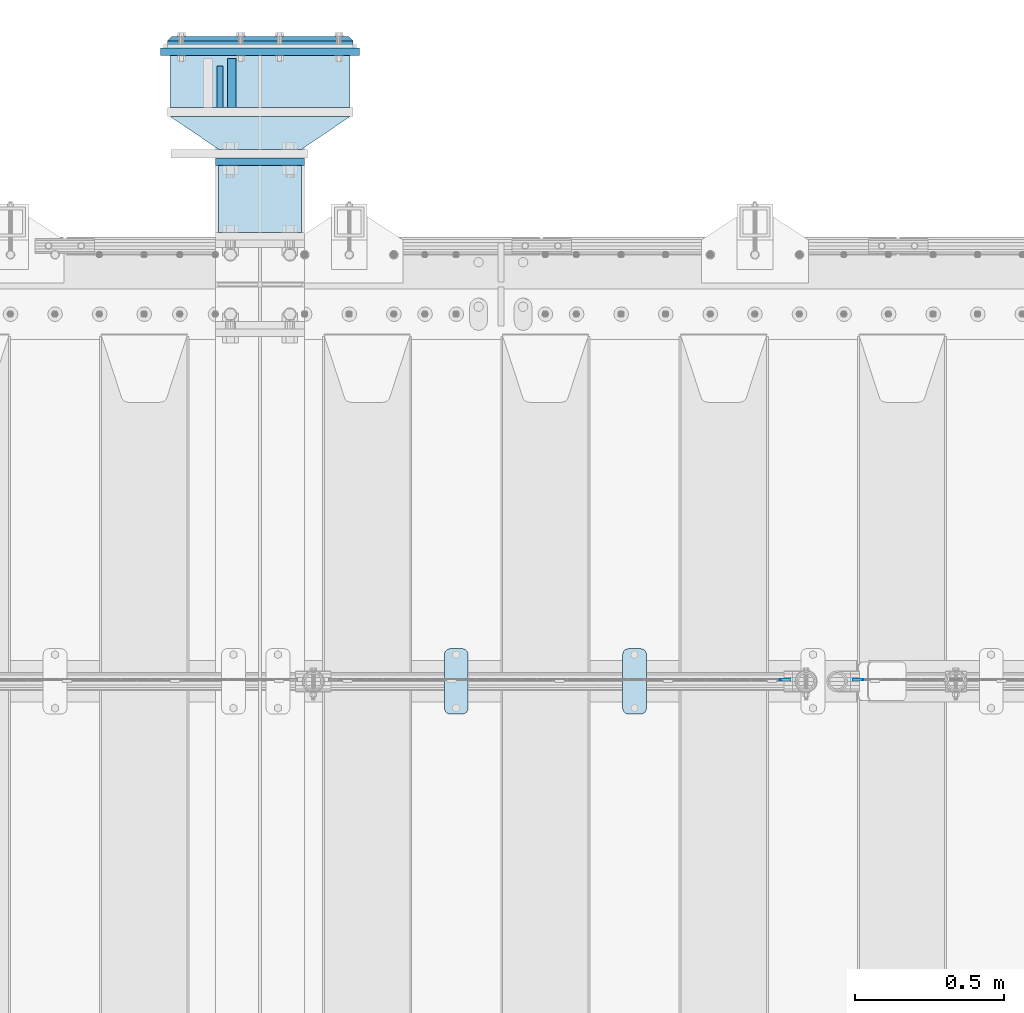
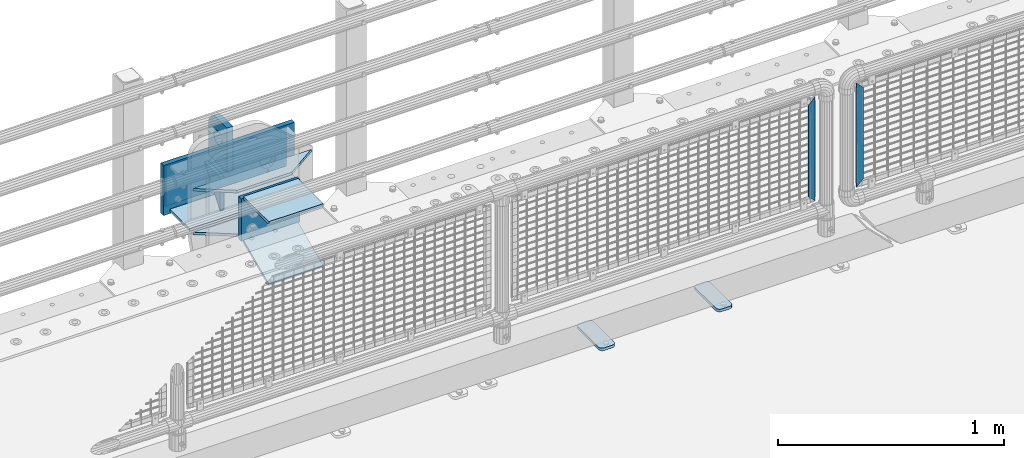
# One storey, part 201 of 219: 14 plates.
"""IFC2X3 building model written with IfcOpenShell, lengths in millimetres."""

import ifcopenshell
import ifcopenshell.guid

model = None  # the IFC model being written
_history = None  # IfcOwnerHistory: only IFC2X3 demands one
_inside = {}  # id of a spatial element -> (the spatial element, [elements in it])
_under = {}  # id of a project, library or spatial element -> (it, [spatial elements below it])
_declared = {}  # id of a project -> (the project, [libraries it declares])
_typed = {}  # id of a type object -> (the type object, [elements of that type])
_made_of = {}  # id of a material, layer set ... -> (it, [elements and type objects made of it])


def new_model(schema):
    """Start an empty IFC model of exactly this schema.

    Asked for "IFC4X3", IfcOpenShell would pick the latest addendum, in which some entities
    have other attributes; the version numbers below select the first issue.
    IFC2X3 requires an IfcOwnerHistory on every rooted entity: one is made here for all.
    """
    global model, _history
    if schema == "IFC4X3":
        model = ifcopenshell.file(schema_version=(4, 3, 0, 0))
    else:
        model = ifcopenshell.file(schema=schema)
    _inside.clear()
    _under.clear()
    _declared.clear()
    _typed.clear()
    _made_of.clear()
    _history = None
    if model.schema == "IFC2X3":
        org = make("IfcOrganization", Name="unknown")
        user = make(
            "IfcPersonAndOrganization",
            ThePerson=make("IfcPerson", FamilyName="unknown"),
            TheOrganization=org,
        )
        app = make(
            "IfcApplication",
            ApplicationDeveloper=org,
            Version="unknown",
            ApplicationFullName="unknown",
            ApplicationIdentifier="unknown",
        )
        _history = make(
            "IfcOwnerHistory",
            OwningUser=user,
            OwningApplication=app,
            ChangeAction="ADDED",
            CreationDate=0,
        )
    return model


def make(cls, **values):
    """One entity of the class cls with the attributes given. An attribute that is None is left unset."""
    return model.create_entity(
        cls, **{name: value for name, value in values.items() if value is not None}
    )


def rooted(cls, **values):
    """An entity with a GlobalId (a new one), such as an element, a storey or a relation."""
    return make(cls, GlobalId=ifcopenshell.guid.new(), OwnerHistory=_history, **values)


def si_unit(unit_type, name, prefix=None):
    """IfcSIUnit, for example si_unit("LENGTHUNIT", "METRE", prefix="MILLI")."""
    return make("IfcSIUnit", UnitType=unit_type, Prefix=prefix, Name=name)


def assignment(units):
    """IfcUnitAssignment: the units of a project."""
    return None if units is None else make("IfcUnitAssignment", Units=units)


def point(xyz):
    """IfcCartesianPoint."""
    return None if xyz is None else make("IfcCartesianPoint", Coordinates=xyz)


def direction(xyz):
    """IfcDirection."""
    return None if xyz is None else make("IfcDirection", DirectionRatios=xyz)


def frame(location, z_axis=None, x_axis=None):
    """IfcAxis2Placement3D, a coordinate frame: its origin and axes. An axis left out is left unset."""
    return make(
        "IfcAxis2Placement3D",
        Location=point(location),
        Axis=direction(z_axis),
        RefDirection=direction(x_axis),
    )


def origin_with_axes():
    """The frame at (0, 0, 0) with the z axis (0, 0, 1) and the x axis (1, 0, 0) written out."""
    return frame((0.0, 0.0, 0.0), z_axis=(0.0, 0.0, 1.0), x_axis=(1.0, 0.0, 0.0))


def place(relative_to, where):
    """IfcLocalPlacement: puts the frame where relative to a parent placement (None: the world)."""
    return make(
        "IfcLocalPlacement", PlacementRelTo=relative_to, RelativePlacement=where
    )


def context(
    kind, dimensions, precision=None, world=None, true_north=None, identifier=None
):
    """IfcGeometricRepresentationContext, for example the 3D "Model" context."""
    return make(
        "IfcGeometricRepresentationContext",
        ContextIdentifier=identifier,
        ContextType=kind,
        CoordinateSpaceDimension=dimensions,
        Precision=precision,
        WorldCoordinateSystem=world,
        TrueNorth=true_north,
    )


def subcontext(parent, identifier, kind, view, scale=None):
    """IfcGeometricRepresentationSubContext, for example "Body" below "Model"."""
    return make(
        "IfcGeometricRepresentationSubContext",
        ContextIdentifier=identifier,
        ContextType=kind,
        ParentContext=parent,
        TargetScale=scale,
        TargetView=view,
    )


def project(units=None, contexts=None):
    """IfcProject with its units and contexts."""
    return rooted(
        "IfcProject",
        Name="project",
        RepresentationContexts=contexts,
        UnitsInContext=assignment(units),
    )


def spatial(cls, under=None, at=None, **own):
    """A site, building, storey or space (cls), placed at a placement, below another one or the project."""
    s = rooted(cls, ObjectPlacement=at, **own)
    if under is not None:
        _under.setdefault(under.id(), (under, []))[1].append(s)
    return s


def faces_of(points, faces, orient=None, outer=None):
    """IfcFace entities. A face is a list of loops; a loop is a list of indices into points, from 0.

    orient and outer hold one flag for each loop. By default every Orientation is true, the
    first loop of a face is its IfcFaceOuterBound and the others are IfcFaceBound.
    """
    made = []
    for i, loops in enumerate(faces):
        bounds = []
        for j, loop in enumerate(loops):
            is_outer = j == 0 if outer is None else outer[i][j]
            bounds.append(
                make(
                    "IfcFaceOuterBound" if is_outer else "IfcFaceBound",
                    Bound=make("IfcPolyLoop", Polygon=[points[k] for k in loop]),
                    Orientation=True if orient is None else orient[i][j],
                )
            )
        made.append(make("IfcFace", Bounds=bounds))
    return made


def faceted_brep(points, faces, orient=None, outer=None, voids=None):
    """IfcFacetedBrep: a solid bounded by flat faces; with voids (closed shells), ...WithVoids."""
    shared = [point(p) for p in points]
    hull = make("IfcClosedShell", CfsFaces=faces_of(shared, faces, orient, outer))
    if voids is None:
        return make("IfcFacetedBrep", Outer=hull)
    return make(
        "IfcFacetedBrepWithVoids",
        Outer=hull,
        Voids=[
            make(cls, CfsFaces=faces_of(shared, fs, o, b)) for cls, fs, o, b in voids
        ],
    )


def shape(context_of_items, identifier, shape_type, items):
    """IfcShapeRepresentation: the items that make up one representation, for example the "Body"."""
    return make(
        "IfcShapeRepresentation",
        ContextOfItems=context_of_items,
        RepresentationIdentifier=identifier,
        RepresentationType=shape_type,
        Items=items,
    )


def material(Name=None, Category=None):
    """IfcMaterial."""
    return make("IfcMaterial", Name=Name, Category=Category)


def made_of(thing, what):
    """Note that an element or type object is made of a material, layer set ...; save() writes the relation."""
    if what is not None:
        _made_of.setdefault(what.id(), (what, []))[1].append(thing)
    return thing


def type_object(cls, material=None, **own):
    """A type object (cls), such as IfcWallType, which elements share."""
    return made_of(rooted(cls, **own), material)


def element(
    cls,
    number,
    at=None,
    inside=None,
    cuts=None,
    type_object=None,
    material=None,
    context=None,
    identifier="Body",
    shape_type=None,
    held_by="IfcProductDefinitionShape",
    body=None,
    shapes=None,
    **own,
):
    """One element of the class cls, such as IfcWall. Its Tag is "e" and its number.

    at: its placement. inside: the storey or other place that contains it. cuts: it is an
    opening in that element (IfcRelVoidsElement). A single representation is given by context,
    identifier, shape_type and body (its items); several are given by shapes. held_by: the class
    of the entity that holds the representations. save() writes the other relations.
    """
    e = rooted(cls, Tag="e%d" % number, ObjectPlacement=at, **own)
    if body is not None:
        shapes = [shape(context, identifier, shape_type, body)]
    if shapes is not None:
        e.Representation = make(held_by, Representations=shapes)
    if inside is not None:
        _inside.setdefault(inside.id(), (inside, []))[1].append(e)
    if cuts is not None:
        rooted(
            "IfcRelVoidsElement", RelatingBuildingElement=cuts, RelatedOpeningElement=e
        )
    if type_object is not None:
        _typed.setdefault(type_object.id(), (type_object, []))[1].append(e)
    return made_of(e, material)


def aggregate(whole, parts):
    """IfcRelAggregates: a whole, such as a stair, and the parts it consists of."""
    return rooted("IfcRelAggregates", RelatingObject=whole, RelatedObjects=parts)


def save(model, path):
    """Write the relations noted so far, then the file.

    IfcRelAggregates (storeys below a building ...), IfcRelContainedInSpatialStructure (elements
    in a storey), IfcRelDefinesByType, IfcRelAssociatesMaterial and IfcRelDeclares: one each for
    every whole, place, type object, material and project.
    """
    for whole, parts in _under.values():
        aggregate(whole, parts)
    for where, things in _inside.values():
        rooted(
            "IfcRelContainedInSpatialStructure",
            RelatedElements=things,
            RelatingStructure=where,
        )
    for kind, things in _typed.values():
        rooted("IfcRelDefinesByType", RelatedObjects=things, RelatingType=kind)
    for what, things in _made_of.values():
        rooted("IfcRelAssociatesMaterial", RelatedObjects=things, RelatingMaterial=what)
    for by, libraries in _declared.values():
        rooted("IfcRelDeclares", RelatingContext=by, RelatedDefinitions=libraries)
    model.write(path)


model = new_model("IFC2X3")

# Units and contexts
model_context = context("Model", 3, precision=1e-05, world=origin_with_axes())
body_context = subcontext(model_context, "Body", "Model", "MODEL_VIEW")
ifc_project = project(units=[si_unit("LENGTHUNIT", "METRE", prefix="MILLI"), si_unit("AREAUNIT", "SQUARE_METRE"), si_unit("VOLUMEUNIT", "CUBIC_METRE"), si_unit("MASSUNIT", "GRAM", prefix="KILO"), si_unit("TIMEUNIT", "SECOND"), si_unit("PLANEANGLEUNIT", "RADIAN"), si_unit("SOLIDANGLEUNIT", "STERADIAN"), si_unit("THERMODYNAMICTEMPERATUREUNIT", "DEGREE_CELSIUS"), si_unit("LUMINOUSINTENSITYUNIT", "LUMEN")], contexts=[model_context])

# Site, building, storey
site_placement = place(None, origin_with_axes())
site = spatial("IfcSite", under=ifc_project, at=site_placement, CompositionType="ELEMENT")
building_placement = place(site_placement, origin_with_axes())
building = spatial("IfcBuilding", under=site, at=building_placement, Name="Standard", CompositionType="ELEMENT")
storey_placement = place(building_placement, origin_with_axes())
storey = spatial("IfcBuildingStorey", under=building, at=storey_placement, Name="Undefined", CompositionType="ELEMENT", Elevation=0.0)

# Plates
ifc_material_1 = material(Name="STEEL/S355N")
plate_type_1 = type_object("IfcPlateType", PredefinedType="NOTDEFINED")
plate_1_placement = place(storey_placement, frame((10294.4999999781, 33594.9999999848, -1.82383710125578e-05), z_axis=(0.0, 1.0, 0.0), x_axis=(0.0, 0.0, 1.0)))
element("IfcPlate", 1, at=plate_1_placement, inside=storey, type_object=plate_type_1, material=ifc_material_1, context=body_context, shape_type="Brep", body=[
    faceted_brep([(125.840713002492, 15.0, 114.183542702915), (125.840713002492, -15.0, 114.183542702915), (113.837049096098, -15.0, 106.162950903905), (113.837049096098, 15.0, 106.162950903905), (105.816457297082, -15.0, 94.1592869975066), (105.816457297082, 15.0, 94.1592869975066), (103.0, -15.0, 80.0), (103.0, 15.0, 80.0), (105.816457297082, -15.0, 65.8407130024934), (105.816457297082, 15.0, 65.8407130024934), (113.837049096098, -15.0, 53.8370490960951), (113.837049096098, 15.0, 53.8370490960951), (125.840713002492, -15.0, 45.8164572970854), (125.840713002492, 15.0, 45.8164572970854), (140.0, -15.0, 43.0), (140.0, 15.0, 43.0), (154.159286997508, -15.0, 45.8164572970854), (154.159286997508, 15.0, 45.8164572970854), (166.162950903902, -15.0, 53.8370490960951), (166.162950903902, 15.0, 53.8370490960951), (174.183542702918, -15.0, 65.8407130024934), (174.183542702918, 15.0, 65.8407130024934), (177.0, -15.0, 80.0), (177.0, 15.0, 80.0), (174.183542702918, -15.0, 94.1592869975066), (174.183542702918, 15.0, 94.1592869975066), (166.162950903902, -15.0, 106.162950903905), (166.162950903902, 15.0, 106.162950903905), (154.159286997508, -15.0, 114.183542702915), (154.159286997508, 15.0, 114.183542702915), (140.0, -15.0, 117.0), (140.0, 15.0, 117.0), (0.0, -15.0, 165.0), (170.0, -15.0, 165.0), (170.0, 15.0, 165.0), (0.0, 15.0, 165.0), (188.117333157176, -15.0, 162.614807840233), (188.117333157176, 15.0, 162.614807840233), (205.0, -15.0, 155.621778264911), (205.0, 15.0, 155.621778264911), (219.497474683058, -15.0, 144.497474683056), (219.497474683058, 15.0, 144.497474683056), (230.621778264911, -15.0, 130.0), (230.621778264911, 15.0, 130.0), (237.614807840235, -15.0, 113.117333157177), (237.614807840235, 15.0, 113.117333157177), (240.0, -15.0, 95.0), (240.0, 15.0, 95.0), (240.0, -15.0, 0.0), (240.0, 15.0, 0.0), (0.0, -15.0, 0.0), (0.0, 15.0, 0.0)], [[[0, 1, 2, 3]], [[3, 2, 4, 5]], [[5, 4, 6, 7]], [[7, 6, 8, 9]], [[9, 8, 10, 11]], [[11, 10, 12, 13]], [[13, 12, 14, 15]], [[15, 14, 16, 17]], [[17, 16, 18, 19]], [[19, 18, 20, 21]], [[21, 20, 22, 23]], [[23, 22, 24, 25]], [[25, 24, 26, 27]], [[27, 26, 28, 29]], [[29, 28, 30, 31]], [[31, 30, 1, 0]], [[32, 33, 34, 35]], [[33, 36, 37, 34]], [[36, 38, 39, 37]], [[38, 40, 41, 39]], [[40, 42, 43, 41]], [[42, 44, 45, 43]], [[44, 46, 47, 45]], [[46, 48, 49, 47]], [[48, 50, 51, 49]], [[34, 37, 39, 41, 43, 45, 47, 49, 51, 35], [3, 5, 7, 9, 11, 13, 15, 17, 19, 21, 23, 25, 27, 29, 31, 0]], [[50, 32, 35, 51]], [[48, 46, 44, 42, 40, 38, 36, 33, 32, 50], [26, 24, 22, 20, 18, 16, 14, 12, 10, 8, 6, 4, 2, 1, 30, 28]]]),
])
plate_type_2 = type_object("IfcPlateType", PredefinedType="NOTDEFINED")
plate_2_placement = place(storey_placement, frame((10254.4999999781, 33734.9999999848, -14.0000182383419), z_axis=(0.0, 0.0, -1.0), x_axis=(0.0, -1.0, 0.0)))
element("IfcPlate", 2, at=plate_2_placement, inside=storey, type_object=plate_type_2, material=ifc_material_1, context=body_context, shape_type="Brep", body=[
    faceted_brep([(0.0, -10.0, 0.0), (140.0, -10.0, 180.0), (140.0, 10.0, 180.0), (0.0, 10.0, 0.0), (140.0, -10.0, -1.81898940354586e-12), (140.0, 10.0, -1.81898940354586e-12)], [[[0, 1, 2, 3]], [[1, 4, 5, 2]], [[4, 0, 3, 5]], [[5, 3, 2]], [[4, 1, 0]]]),
])
ifc_material_2 = material(Name="Misc_Undefined")
plate_type_3 = type_object("IfcPlateType", PredefinedType="NOTDEFINED")
plate_3_placement = place(storey_placement, frame((12138.4996874836, 31670.5, 879.52), z_axis=(0.707103624179499, 0.0, -0.707109938179501), x_axis=(0.707109938179499, 0.0, 0.707103624179502)))
element("IfcPlate", 3, at=plate_3_placement, inside=storey, type_object=plate_type_3, material=ifc_material_2, context=body_context, shape_type="Brep", body=[
    faceted_brep([(0.0, -1.5, -5.6843418860808e-14), (-348.605163574219, -1.5, 348.602081298829), (-348.605163574219, 1.5, 348.602081298829), (0.0, 1.5, -5.6843418860808e-14), (-348.605163574217, -1.5, 398.0993347168), (-348.605163574217, 1.5, 398.0993347168), (49.4976959228516, -1.5, -1.0550138540566e-10), (49.4976959228516, 1.5, -1.0550138540566e-10)], [[[0, 1, 2, 3]], [[1, 4, 5, 2]], [[4, 6, 7, 5]], [[6, 0, 3, 7]], [[5, 7, 3, 2]], [[6, 4, 1, 0]]]),
])
plate_4_placement = place(storey_placement, frame((12420.1100258824, 31670.4999645044, 879.520017263597), z_axis=(-0.707106781186548, 0.0, -0.707106781186548), x_axis=(-0.707106781186548, 0.0, 0.707106781186548)))
element("IfcPlate", 4, at=plate_4_placement, inside=storey, type_object=plate_type_3, material=ifc_material_2, context=body_context, shape_type="Brep", body=[
    faceted_brep([(0.0, -1.5, -5.6843418860808e-14), (-348.603637695373, -1.5, 348.603668212892), (-348.603637695373, 1.5, 348.603668212892), (0.0, 1.5, -5.6843418860808e-14), (-348.60363769538, -1.5, 398.101165771486), (-348.60363769538, 1.5, 398.101165771486), (49.4974975585938, -1.5, 2.36468622460961e-11), (49.4974975585947, 1.5, 2.36468622460961e-11)], [[[0, 1, 2, 3]], [[1, 4, 5, 2]], [[4, 6, 7, 5]], [[6, 0, 3, 7]], [[5, 7, 3, 2]], [[6, 4, 1, 0]]]),
])
ifc_material_3 = material(Name="STEEL/S355J2")
plate_type_4 = type_object("IfcPlateType", PredefinedType="NOTDEFINED")
plate_5_placement = place(storey_placement, frame((11610.0, 31774.5, 21.0199999999977), z_axis=(1.0, 0.0, 0.0), x_axis=(0.0, -1.0, 0.0)))
element("IfcPlate", 5, at=plate_5_placement, inside=storey, type_object=plate_type_4, material=ifc_material_3, context=body_context, shape_type="Brep", body=[
    faceted_brep([(0.0, -7.0, 20.0), (0.0, -7.0, 60.0), (0.0, 7.0, 60.0), (0.0, 7.0, 20.0), (0.384294391937146, -7.0, 63.9018064403226), (0.384294391937146, 7.0, 63.9018064403226), (1.52240934977453, -7.0, 67.6536686473009), (1.52240934977453, 7.0, 67.6536686473009), (3.37060775395003, -7.0, 71.1114046603925), (3.37060775395003, 7.0, 71.1114046603925), (5.8578643762703, -7.0, 74.1421356237315), (5.8578643762703, 7.0, 74.1421356237315), (8.88859533960931, -7.0, 76.6293922460518), (8.88859533960931, 7.0, 76.6293922460518), (12.3463313526991, -7.0, 78.4775906502255), (12.3463313526991, 7.0, 78.4775906502255), (16.0981935596792, -7.0, 79.6157056080647), (16.0981935596792, 7.0, 79.6157056080647), (20.0, -7.0, 80.0), (20.0, 7.0, 80.0), (200.0, -7.0, 80.0), (200.0, 7.0, 80.0), (203.901806440321, -7.0, 79.6157056080647), (203.901806440321, 7.0, 79.6157056080647), (207.653668647301, -7.0, 78.4775906502255), (207.653668647301, 7.0, 78.4775906502255), (211.111404660391, -7.0, 76.6293922460518), (211.111404660391, 7.0, 76.6293922460518), (214.14213562373, -7.0, 74.1421356237315), (214.14213562373, 7.0, 74.1421356237315), (216.62939224605, -7.0, 71.1114046603925), (216.62939224605, 7.0, 71.1114046603925), (218.477590650225, -7.0, 67.6536686473009), (218.477590650225, 7.0, 67.6536686473009), (219.615705608063, -7.0, 63.9018064403226), (219.615705608063, 7.0, 63.9018064403226), (220.0, -7.0, 60.0), (220.0, 7.0, 60.0), (220.0, -7.0, 20.0), (220.0, 7.0, 20.0), (219.615705608063, -7.0, 16.0981935596774), (219.615705608063, 7.0, 16.0981935596774), (218.477590650225, -7.0, 12.3463313526991), (218.477590650225, 7.0, 12.3463313526991), (216.62939224605, -7.0, 8.88859533960749), (216.62939224605, 7.0, 8.88859533960749), (214.14213562373, -7.0, 5.85786437626848), (214.14213562373, 7.0, 5.85786437626848), (211.111404660391, -7.0, 3.37060775394821), (211.111404660391, 7.0, 3.37060775394821), (207.653668647301, -7.0, 1.52240934977453), (207.653668647301, 7.0, 1.52240934977453), (203.901806440321, -7.0, 0.384294391935327), (203.901806440321, 7.0, 0.384294391935327), (200.0, -7.0, 0.0), (200.0, 7.0, 0.0), (20.0, -7.0, 0.0), (20.0, 7.0, 0.0), (16.0981935596792, -7.0, 0.384294391935327), (16.0981935596792, 7.0, 0.384294391935327), (12.3463313526991, -7.0, 1.52240934977453), (12.3463313526991, 7.0, 1.52240934977453), (8.88859533960931, -7.0, 3.37060775394821), (8.88859533960931, 7.0, 3.37060775394821), (5.8578643762703, -7.0, 5.85786437626848), (5.8578643762703, 7.0, 5.85786437626848), (3.37060775395003, -7.0, 8.88859533960749), (3.37060775395003, 7.0, 8.88859533960749), (1.52240934977453, -7.0, 12.3463313526991), (1.52240934977453, 7.0, 12.3463313526991), (0.384294391937146, -7.0, 16.0981935596774), (0.384294391937146, 7.0, 16.0981935596774)], [[[0, 1, 2, 3]], [[1, 4, 5, 2]], [[4, 6, 7, 5]], [[6, 8, 9, 7]], [[8, 10, 11, 9]], [[10, 12, 13, 11]], [[12, 14, 15, 13]], [[14, 16, 17, 15]], [[16, 18, 19, 17]], [[18, 20, 21, 19]], [[20, 22, 23, 21]], [[22, 24, 25, 23]], [[24, 26, 27, 25]], [[26, 28, 29, 27]], [[28, 30, 31, 29]], [[30, 32, 33, 31]], [[32, 34, 35, 33]], [[34, 36, 37, 35]], [[36, 38, 39, 37]], [[38, 40, 41, 39]], [[40, 42, 43, 41]], [[42, 44, 45, 43]], [[44, 46, 47, 45]], [[46, 48, 49, 47]], [[48, 50, 51, 49]], [[50, 52, 53, 51]], [[52, 54, 55, 53]], [[54, 56, 57, 55]], [[56, 58, 59, 57]], [[58, 60, 61, 59]], [[60, 62, 63, 61]], [[62, 64, 65, 63]], [[64, 66, 67, 65]], [[66, 68, 69, 67]], [[68, 70, 71, 69]], [[70, 0, 3, 71]], [[5, 7, 9, 11, 13, 15, 17, 19, 21, 23, 25, 27, 29, 31, 33, 35, 37, 39, 41, 43, 45, 47, 49, 51, 53, 55, 57, 59, 61, 63, 65, 67, 69, 71, 3, 2]], [[70, 68, 66, 64, 62, 60, 58, 56, 54, 52, 50, 48, 46, 44, 42, 40, 38, 36, 34, 32, 30, 28, 26, 24, 22, 20, 18, 16, 14, 12, 10, 8, 6, 4, 1, 0]]]),
])
plate_6_placement = place(storey_placement, frame((11010.0, 31774.5, 21.0199999999977), z_axis=(1.0, 0.0, 0.0), x_axis=(0.0, -1.0, 0.0)))
element("IfcPlate", 6, at=plate_6_placement, inside=storey, type_object=plate_type_4, material=ifc_material_3, context=body_context, shape_type="Brep", body=[
    faceted_brep([(0.0, -7.0, 20.0), (0.0, -7.0, 60.0), (0.0, 7.0, 60.0), (0.0, 7.0, 20.0), (0.384294391937146, -7.0, 63.9018064403226), (0.384294391937146, 7.0, 63.9018064403226), (1.52240934977453, -7.0, 67.6536686473009), (1.52240934977453, 7.0, 67.6536686473009), (3.37060775395003, -7.0, 71.1114046603925), (3.37060775395003, 7.0, 71.1114046603925), (5.8578643762703, -7.0, 74.1421356237315), (5.8578643762703, 7.0, 74.1421356237315), (8.88859533960931, -7.0, 76.6293922460518), (8.88859533960931, 7.0, 76.6293922460518), (12.3463313526991, -7.0, 78.4775906502255), (12.3463313526991, 7.0, 78.4775906502255), (16.0981935596792, -7.0, 79.6157056080647), (16.0981935596792, 7.0, 79.6157056080647), (20.0, -7.0, 80.0), (20.0, 7.0, 80.0), (200.0, -7.0, 80.0), (200.0, 7.0, 80.0), (203.901806440321, -7.0, 79.6157056080647), (203.901806440321, 7.0, 79.6157056080647), (207.653668647301, -7.0, 78.4775906502255), (207.653668647301, 7.0, 78.4775906502255), (211.111404660391, -7.0, 76.6293922460518), (211.111404660391, 7.0, 76.6293922460518), (214.14213562373, -7.0, 74.1421356237315), (214.14213562373, 7.0, 74.1421356237315), (216.62939224605, -7.0, 71.1114046603925), (216.62939224605, 7.0, 71.1114046603925), (218.477590650225, -7.0, 67.6536686473009), (218.477590650225, 7.0, 67.6536686473009), (219.615705608063, -7.0, 63.9018064403226), (219.615705608063, 7.0, 63.9018064403226), (220.0, -7.0, 60.0), (220.0, 7.0, 60.0), (220.0, -7.0, 20.0), (220.0, 7.0, 20.0), (219.615705608063, -7.0, 16.0981935596774), (219.615705608063, 7.0, 16.0981935596774), (218.477590650225, -7.0, 12.3463313526991), (218.477590650225, 7.0, 12.3463313526991), (216.62939224605, -7.0, 8.88859533960749), (216.62939224605, 7.0, 8.88859533960749), (214.14213562373, -7.0, 5.85786437626848), (214.14213562373, 7.0, 5.85786437626848), (211.111404660391, -7.0, 3.37060775394821), (211.111404660391, 7.0, 3.37060775394821), (207.653668647301, -7.0, 1.52240934977453), (207.653668647301, 7.0, 1.52240934977453), (203.901806440321, -7.0, 0.384294391935327), (203.901806440321, 7.0, 0.384294391935327), (200.0, -7.0, 0.0), (200.0, 7.0, 0.0), (20.0, -7.0, 0.0), (20.0, 7.0, 0.0), (16.0981935596792, -7.0, 0.384294391935327), (16.0981935596792, 7.0, 0.384294391935327), (12.3463313526991, -7.0, 1.52240934977453), (12.3463313526991, 7.0, 1.52240934977453), (8.88859533960931, -7.0, 3.37060775394821), (8.88859533960931, 7.0, 3.37060775394821), (5.8578643762703, -7.0, 5.85786437626848), (5.8578643762703, 7.0, 5.85786437626848), (3.37060775395003, -7.0, 8.88859533960749), (3.37060775395003, 7.0, 8.88859533960749), (1.52240934977453, -7.0, 12.3463313526991), (1.52240934977453, 7.0, 12.3463313526991), (0.384294391937146, -7.0, 16.0981935596774), (0.384294391937146, 7.0, 16.0981935596774)], [[[0, 1, 2, 3]], [[1, 4, 5, 2]], [[4, 6, 7, 5]], [[6, 8, 9, 7]], [[8, 10, 11, 9]], [[10, 12, 13, 11]], [[12, 14, 15, 13]], [[14, 16, 17, 15]], [[16, 18, 19, 17]], [[18, 20, 21, 19]], [[20, 22, 23, 21]], [[22, 24, 25, 23]], [[24, 26, 27, 25]], [[26, 28, 29, 27]], [[28, 30, 31, 29]], [[30, 32, 33, 31]], [[32, 34, 35, 33]], [[34, 36, 37, 35]], [[36, 38, 39, 37]], [[38, 40, 41, 39]], [[40, 42, 43, 41]], [[42, 44, 45, 43]], [[44, 46, 47, 45]], [[46, 48, 49, 47]], [[48, 50, 51, 49]], [[50, 52, 53, 51]], [[52, 54, 55, 53]], [[54, 56, 57, 55]], [[56, 58, 59, 57]], [[58, 60, 61, 59]], [[60, 62, 63, 61]], [[62, 64, 65, 63]], [[64, 66, 67, 65]], [[66, 68, 69, 67]], [[68, 70, 71, 69]], [[70, 0, 3, 71]], [[5, 7, 9, 11, 13, 15, 17, 19, 21, 23, 25, 27, 29, 31, 33, 35, 37, 39, 41, 43, 45, 47, 49, 51, 53, 55, 57, 59, 61, 63, 65, 67, 69, 71, 3, 2]], [[70, 68, 66, 64, 62, 60, 58, 56, 54, 52, 50, 48, 46, 44, 42, 40, 38, 36, 34, 32, 30, 28, 26, 24, 22, 20, 18, 16, 14, 12, 10, 8, 6, 4, 1, 0]]]),
])
ifc_material_4 = material()
plate_type_5 = type_object("IfcPlateType", PredefinedType="NOTDEFINED")
plate_7_placement = place(storey_placement, frame((10692.4999999781, 33594.9999999848, -243.000018238371), z_axis=(0.0, 1.0, 0.0), x_axis=(-1.0, 0.0, 0.0)))
element("IfcPlate", 7, at=plate_7_placement, inside=storey, type_object=plate_type_5, material=ifc_material_4, context=body_context, shape_type="Brep", body=[
    faceted_brep([(0.0, -7.0, 0.0), (0.0, -7.0, 175.0), (0.0, 7.0, 175.0), (0.0, 7.0, 0.0), (605.0, -7.0, 175.0), (605.0, 7.0, 175.0), (605.0, -7.0, 0.0), (605.0, 7.0, 0.0)], [[[0, 1, 2, 3]], [[1, 4, 5, 2]], [[4, 6, 7, 5]], [[6, 0, 3, 7]], [[5, 7, 3, 2]], [[6, 4, 1, 0]]]),
])
plate_type_6 = type_object("IfcPlateType", PredefinedType="NOTDEFINED")
for number, where, z_axis, x_axis in (
    (8, (10692.4999999781, 33564.9999999848, -7.00001823837101), (-0.560566412034008, 0.828109472050235, 0.0), (-0.828109472050229, -0.560566412034016, 0.0)),
    (9, (10692.4999999781, 33564.9999999848, -243.000018238371), (-0.560566412034008, 0.828109472050235, 0.0), (-0.828109472050229, -0.560566412034016, 0.0)),
):
    element("IfcPlate", number, at=place(storey_placement, frame(where, z_axis=z_axis, x_axis=x_axis)), inside=storey, type_object=plate_type_6, material=ifc_material_1, context=body_context, shape_type="Brep", body=[
        faceted_brep([(0.0, -7.0, 0.0), (501.006225585941, -7.0, 339.142669677731), (501.006225585941, 7.0, 339.142669677731), (0.0, 7.0, 0.0), (428.100738525394, -7.0, 156.95860290527), (428.100738525394, 7.0, 156.95860290527), (196.230087280277, -7.0, 2.58296495303512e-10), (196.230087280277, 7.0, 2.58296495303512e-10)], [[[0, 1, 2, 3]], [[1, 4, 5, 2]], [[4, 6, 7, 5]], [[6, 0, 3, 7]], [[5, 7, 3, 2]], [[6, 4, 1, 0]]]),
    ])
plate_type_7 = type_object("IfcPlateType", PredefinedType="NOTDEFINED")
plate_8_placement = place(storey_placement, frame((10724.9999999781, 33782.4999999848, 9.99998176162899), z_axis=(0.0, 0.0, -1.0), x_axis=(-1.0, 0.0, 0.0)))
element("IfcPlate", 10, at=plate_8_placement, inside=storey, type_object=plate_type_7, material=ifc_material_1, context=body_context, shape_type="Brep", body=[
    faceted_brep([(0.0, -12.5, 0.0), (0.0, -12.5, 270.0), (0.0, 12.5, 270.0), (0.0, 12.5, 0.0), (670.0, -12.5, 270.0), (670.0, 12.5, 270.0), (670.0, -12.5, 0.0), (670.0, 12.5, 0.0)], [[[0, 1, 2, 3]], [[1, 4, 5, 2]], [[4, 6, 7, 5]], [[6, 0, 3, 7]], [[5, 7, 3, 2]], [[6, 4, 1, 0]]]),
])
plate_type_8 = type_object("IfcPlateType", PredefinedType="NOTDEFINED")
plate_9_placement = place(storey_placement, frame((10239.9999999781, 33412.4999999848, -240.000018238371), z_axis=(0.0, 0.0, 1.0), x_axis=(1.0, 0.0, 0.0)))
element("IfcPlate", 11, at=plate_9_placement, inside=storey, type_object=plate_type_8, material=ifc_material_1, context=body_context, shape_type="Brep", body=[
    faceted_brep([(0.0, -12.5, 0.0), (0.0, -12.5, 230.0), (0.0, 12.5, 230.0), (0.0, 12.5, 0.0), (300.0, -12.5, 230.0), (300.0, 12.5, 230.0), (300.0, -12.5, 0.0), (300.0, 12.5, 0.0)], [[[0, 1, 2, 3]], [[1, 4, 5, 2]], [[4, 6, 7, 5]], [[6, 0, 3, 7]], [[5, 7, 3, 2]], [[6, 4, 1, 0]]]),
])
ifc_material_5 = material()
plate_type_9 = type_object("IfcPlateType", PredefinedType="NOTDEFINED")
plate_10_placement = place(storey_placement, frame((10702.4999999781, 33814.9999999848, -12.500018238371), z_axis=(0.0, 0.0, -1.0), x_axis=(-1.0, 0.0, 0.0)))
element("IfcPlate", 12, at=plate_10_placement, inside=storey, type_object=plate_type_9, material=ifc_material_5, context=body_context, shape_type="Brep", body=[
    faceted_brep([(0.0, -15.0, 0.0), (5.0, -20.0, 5.0), (5.0, -20.0, 220.0), (0.0, -15.0, 225.0), (625.0, -15.0, 0.0), (620.0, -20.0, 5.0), (620.0, -20.0, 220.0), (625.0, -15.0, 225.0), (15.0, 20.0, 15.0), (0.0, 5.0, 0.0), (0.0, 5.0, 225.0), (15.0, 20.0, 210.0), (625.0, 5.0, 225.0), (610.0, 20.0, 210.0), (625.0, 5.0, 0.0), (610.0, 20.0, 15.0), (64.8205080756888, -5.0, 37.4999999999998), (57.5, -5.0, 30.179491924311), (47.5, -5.0, 27.4999999999998), (37.5, -5.0, 30.179491924311), (30.1794919243112, -5.0, 37.4999999999998), (27.5, -5.0, 47.4999999999998), (30.1794919243112, -5.0, 57.4999999999998), (37.5, -5.0, 64.8205080756885), (47.5, -5.0, 67.4999999999998), (57.5, -5.0, 64.8205080756886), (64.8205080756888, -5.0, 57.4999999999998), (67.5, -5.0, 47.4999999999998), (37.5, 20.0, 64.8205080756885), (30.1794919243112, 20.0, 57.4999999999998), (47.5, 20.0, 67.4999999999998), (57.5, 20.0, 64.8205080756886), (64.8205080756888, 20.0, 57.4999999999998), (67.5, 20.0, 47.4999999999998), (64.8205080756888, 20.0, 37.4999999999998), (57.5, 20.0, 30.179491924311), (47.5, 20.0, 27.4999999999998), (37.5, 20.0, 30.179491924311), (30.1794919243112, 20.0, 37.4999999999998), (27.5, 20.0, 47.4999999999998), (394.820508075689, -5.0, 37.4999999999998), (387.5, -5.0, 30.179491924311), (377.5, -5.0, 27.4999999999998), (367.5, -5.0, 30.179491924311), (360.179491924311, -5.0, 37.4999999999998), (357.5, -5.0, 47.4999999999998), (360.179491924311, -5.0, 57.4999999999998), (367.5, -5.0, 64.8205080756885), (377.5, -5.0, 67.4999999999998), (387.5, -5.0, 64.8205080756886), (394.820508075689, -5.0, 57.4999999999998), (397.5, -5.0, 47.4999999999998), (360.179491924311, 20.0, 57.4999999999998), (357.5, 20.0, 47.4999999999998), (367.5, 20.0, 64.8205080756885), (377.5, 20.0, 67.4999999999998), (387.5, 20.0, 64.8205080756886), (394.820508075689, 20.0, 57.4999999999998), (397.5, 20.0, 47.4999999999998), (394.820508075689, 20.0, 37.4999999999998), (387.5, 20.0, 30.179491924311), (377.5, 20.0, 27.4999999999998), (367.5, 20.0, 30.179491924311), (360.179491924311, 20.0, 37.4999999999998), (394.820508075689, -5.0, 167.5), (387.5, -5.0, 160.179491924311), (377.5, -5.0, 157.5), (367.5, -5.0, 160.179491924311), (360.179491924311, -5.0, 167.5), (357.5, -5.0, 177.5), (360.179491924311, -5.0, 187.5), (367.5, -5.0, 194.820508075689), (377.5, -5.0, 197.5), (387.5, -5.0, 194.820508075689), (394.820508075689, -5.0, 187.5), (397.5, -5.0, 177.5), (360.179491924311, 20.0, 187.5), (357.5, 20.0, 177.5), (367.5, 20.0, 194.820508075689), (377.5, 20.0, 197.5), (387.5, 20.0, 194.820508075689), (394.820508075689, 20.0, 187.5), (397.5, 20.0, 177.5), (394.820508075689, 20.0, 167.5), (387.5, 20.0, 160.179491924311), (377.5, 20.0, 157.5), (367.5, 20.0, 160.179491924311), (360.179491924311, 20.0, 167.5), (594.820508075689, -5.0, 167.5), (587.5, -5.0, 160.179491924311), (577.5, -5.0, 157.5), (567.5, -5.0, 160.179491924311), (560.179491924311, -5.0, 167.5), (557.5, -5.0, 177.5), (560.179491924311, -5.0, 187.5), (567.5, -5.0, 194.820508075689), (577.5, -5.0, 197.5), (587.5, -5.0, 194.820508075689), (594.820508075689, -5.0, 187.5), (597.5, -5.0, 177.5), (560.179491924311, 20.0, 187.5), (557.5, 20.0, 177.5), (567.5, 20.0, 194.820508075689), (577.5, 20.0, 197.5), (587.5, 20.0, 194.820508075689), (594.820508075689, 20.0, 187.5), (597.5, 20.0, 177.5), (594.820508075689, 20.0, 167.5), (587.5, 20.0, 160.179491924311), (577.5, 20.0, 157.5), (567.5, 20.0, 160.179491924311), (560.179491924311, 20.0, 167.5), (264.820508075689, -5.0, 37.4999999999998), (257.5, -5.0, 30.179491924311), (247.5, -5.0, 27.4999999999998), (237.5, -5.0, 30.179491924311), (230.179491924311, -5.0, 37.4999999999998), (227.5, -5.0, 47.4999999999998), (230.179491924311, -5.0, 57.4999999999998), (237.5, -5.0, 64.8205080756885), (247.5, -5.0, 67.4999999999998), (257.5, -5.0, 64.8205080756886), (264.820508075689, -5.0, 57.4999999999998), (267.5, -5.0, 47.4999999999998), (230.179491924311, 20.0, 57.4999999999998), (227.5, 20.0, 47.4999999999998), (237.5, 20.0, 64.8205080756885), (247.5, 20.0, 67.4999999999998), (257.5, 20.0, 64.8205080756886), (264.820508075689, 20.0, 57.4999999999998), (267.5, 20.0, 47.4999999999998), (264.820508075689, 20.0, 37.4999999999998), (257.5, 20.0, 30.179491924311), (247.5, 20.0, 27.4999999999998), (237.5, 20.0, 30.179491924311), (230.179491924311, 20.0, 37.4999999999998), (64.8205080756888, -5.0, 167.5), (57.5, -5.0, 160.179491924311), (47.5, -5.0, 157.5), (37.5, -5.0, 160.179491924311), (30.1794919243112, -5.0, 167.5), (27.5, -5.0, 177.5), (30.1794919243112, -5.0, 187.5), (37.5, -5.0, 194.820508075689), (47.5, -5.0, 197.5), (57.5, -5.0, 194.820508075689), (64.8205080756888, -5.0, 187.5), (67.5, -5.0, 177.5), (30.1794919243112, 20.0, 187.5), (27.5, 20.0, 177.5), (37.5, 20.0, 194.820508075689), (47.5, 20.0, 197.5), (57.5, 20.0, 194.820508075689), (64.8205080756888, 20.0, 187.5), (67.5, 20.0, 177.5), (64.8205080756888, 20.0, 167.5), (57.5, 20.0, 160.179491924311), (47.5, 20.0, 157.5), (37.5, 20.0, 160.179491924311), (30.1794919243112, 20.0, 167.5), (264.820508075689, -5.0, 167.5), (257.5, -5.0, 160.179491924311), (247.5, -5.0, 157.5), (237.5, -5.0, 160.179491924311), (230.179491924311, -5.0, 167.5), (227.5, -5.0, 177.5), (230.179491924311, -5.0, 187.5), (237.5, -5.0, 194.820508075689), (247.5, -5.0, 197.5), (257.5, -5.0, 194.820508075689), (264.820508075689, -5.0, 187.5), (267.5, -5.0, 177.5), (230.179491924311, 20.0, 187.5), (227.5, 20.0, 177.5), (237.5, 20.0, 194.820508075689), (247.5, 20.0, 197.5), (257.5, 20.0, 194.820508075689), (264.820508075689, 20.0, 187.5), (267.5, 20.0, 177.5), (264.820508075689, 20.0, 167.5), (257.5, 20.0, 160.179491924311), (247.5, 20.0, 157.5), (237.5, 20.0, 160.179491924311), (230.179491924311, 20.0, 167.5), (594.820508075689, -5.0, 37.4999999999998), (587.5, -5.0, 30.179491924311), (577.5, -5.0, 27.4999999999998), (567.5, -5.0, 30.179491924311), (560.179491924311, -5.0, 37.4999999999998), (557.5, -5.0, 47.4999999999998), (560.179491924311, -5.0, 57.4999999999998), (567.5, -5.0, 64.8205080756885), (577.5, -5.0, 67.4999999999998), (587.5, -5.0, 64.8205080756886), (594.820508075689, -5.0, 57.4999999999998), (597.5, -5.0, 47.4999999999998), (560.179491924311, 20.0, 57.4999999999998), (557.5, 20.0, 47.4999999999998), (567.5, 20.0, 64.8205080756885), (577.5, 20.0, 67.4999999999998), (587.5, 20.0, 64.8205080756886), (594.820508075689, 20.0, 57.4999999999998), (597.5, 20.0, 47.4999999999998), (594.820508075689, 20.0, 37.4999999999998), (587.5, 20.0, 30.179491924311), (577.5, 20.0, 27.4999999999998), (567.5, 20.0, 30.179491924311), (560.179491924311, 20.0, 37.4999999999998)], [[[0, 1, 2, 3]], [[4, 5, 1, 0]], [[6, 7, 3, 2]], [[7, 6, 5, 4]], [[8, 9, 10, 11]], [[12, 13, 11, 10]], [[14, 15, 13, 12]], [[15, 14, 9, 8]], [[16, 17, 18, 19, 20, 21, 22, 23, 24, 25, 26, 27]], [[28, 23, 22, 29]], [[30, 24, 23, 28]], [[31, 25, 24, 30]], [[32, 26, 25, 31]], [[33, 27, 26, 32]], [[34, 16, 27, 33]], [[35, 17, 16, 34]], [[36, 18, 17, 35]], [[37, 19, 18, 36]], [[38, 20, 19, 37]], [[39, 21, 20, 38]], [[29, 22, 21, 39]], [[5, 6, 2, 1]], [[9, 14, 4, 0]], [[14, 12, 7, 4]], [[12, 10, 3, 7]], [[10, 9, 0, 3]], [[40, 41, 42, 43, 44, 45, 46, 47, 48, 49, 50, 51]], [[52, 46, 45, 53]], [[54, 47, 46, 52]], [[55, 48, 47, 54]], [[56, 49, 48, 55]], [[57, 50, 49, 56]], [[58, 51, 50, 57]], [[59, 40, 51, 58]], [[60, 41, 40, 59]], [[61, 42, 41, 60]], [[62, 43, 42, 61]], [[63, 44, 43, 62]], [[53, 45, 44, 63]], [[64, 65, 66, 67, 68, 69, 70, 71, 72, 73, 74, 75]], [[76, 70, 69, 77]], [[78, 71, 70, 76]], [[79, 72, 71, 78]], [[80, 73, 72, 79]], [[81, 74, 73, 80]], [[82, 75, 74, 81]], [[83, 64, 75, 82]], [[84, 65, 64, 83]], [[85, 66, 65, 84]], [[86, 67, 66, 85]], [[87, 68, 67, 86]], [[77, 69, 68, 87]], [[88, 89, 90, 91, 92, 93, 94, 95, 96, 97, 98, 99]], [[100, 94, 93, 101]], [[102, 95, 94, 100]], [[103, 96, 95, 102]], [[104, 97, 96, 103]], [[105, 98, 97, 104]], [[106, 99, 98, 105]], [[107, 88, 99, 106]], [[108, 89, 88, 107]], [[109, 90, 89, 108]], [[110, 91, 90, 109]], [[111, 92, 91, 110]], [[101, 93, 92, 111]], [[112, 113, 114, 115, 116, 117, 118, 119, 120, 121, 122, 123]], [[124, 118, 117, 125]], [[126, 119, 118, 124]], [[127, 120, 119, 126]], [[128, 121, 120, 127]], [[129, 122, 121, 128]], [[130, 123, 122, 129]], [[131, 112, 123, 130]], [[132, 113, 112, 131]], [[133, 114, 113, 132]], [[134, 115, 114, 133]], [[135, 116, 115, 134]], [[125, 117, 116, 135]], [[136, 137, 138, 139, 140, 141, 142, 143, 144, 145, 146, 147]], [[148, 142, 141, 149]], [[150, 143, 142, 148]], [[151, 144, 143, 150]], [[152, 145, 144, 151]], [[153, 146, 145, 152]], [[154, 147, 146, 153]], [[155, 136, 147, 154]], [[156, 137, 136, 155]], [[157, 138, 137, 156]], [[158, 139, 138, 157]], [[159, 140, 139, 158]], [[149, 141, 140, 159]], [[160, 161, 162, 163, 164, 165, 166, 167, 168, 169, 170, 171]], [[172, 166, 165, 173]], [[174, 167, 166, 172]], [[175, 168, 167, 174]], [[176, 169, 168, 175]], [[177, 170, 169, 176]], [[178, 171, 170, 177]], [[179, 160, 171, 178]], [[180, 161, 160, 179]], [[181, 162, 161, 180]], [[182, 163, 162, 181]], [[183, 164, 163, 182]], [[173, 165, 164, 183]], [[184, 185, 186, 187, 188, 189, 190, 191, 192, 193, 194, 195]], [[196, 190, 189, 197]], [[198, 191, 190, 196]], [[199, 192, 191, 198]], [[200, 193, 192, 199]], [[201, 194, 193, 200]], [[202, 195, 194, 201]], [[203, 184, 195, 202]], [[204, 185, 184, 203]], [[205, 186, 185, 204]], [[206, 187, 186, 205]], [[207, 188, 187, 206]], [[197, 189, 188, 207]], [[13, 15, 8, 11], [37, 36, 35, 34, 33, 32, 31, 30, 28, 29, 39, 38], [206, 205, 204, 203, 202, 201, 200, 199, 198, 196, 197, 207], [182, 181, 180, 179, 178, 177, 176, 175, 174, 172, 173, 183], [158, 157, 156, 155, 154, 153, 152, 151, 150, 148, 149, 159], [134, 133, 132, 131, 130, 129, 128, 127, 126, 124, 125, 135], [110, 109, 108, 107, 106, 105, 104, 103, 102, 100, 101, 111], [86, 85, 84, 83, 82, 81, 80, 79, 78, 76, 77, 87], [62, 61, 60, 59, 58, 57, 56, 55, 54, 52, 53, 63]]]),
])
plate_type_10 = type_object("IfcPlateType", PredefinedType="NOTDEFINED")
plate_11_placement = place(storey_placement, frame((10249.9999999781, 33174.9999999848, -7.00001823837101), z_axis=(0.0, 1.0, 0.0), x_axis=(1.0, 0.0, 0.0)))
element("IfcPlate", 13, at=plate_11_placement, inside=storey, type_object=plate_type_10, material=ifc_material_1, context=body_context, shape_type="Brep", body=[
    faceted_brep([(0.0, -7.0, 0.0), (0.0, -7.0, 225.0), (0.0, 7.0, 225.0), (0.0, 7.0, 0.0), (280.0, -7.0, 225.0), (280.0, 7.0, 225.0), (280.0, -7.0, 0.0), (280.0, 7.0, 0.0)], [[[0, 1, 2, 3]], [[1, 4, 5, 2]], [[4, 6, 7, 5]], [[6, 0, 3, 7]], [[5, 7, 3, 2]], [[6, 4, 1, 0]]]),
])
plate_type_11 = type_object("IfcPlateType", PredefinedType="NOTDEFINED")
plate_12_placement = place(storey_placement, frame((10249.9999999781, 33177.8429692472, -342.396699078713), z_axis=(0.0, 0.913811548702731, 0.406138465867881), x_axis=(1.0, 0.0, 0.0)))
element("IfcPlate", 14, at=plate_12_placement, inside=storey, type_object=plate_type_11, material=ifc_material_1, context=body_context, shape_type="Brep", body=[
    faceted_brep([(0.0, -7.0, 0.0), (0.0, -6.99999999999818, 246.221450805664), (0.0, 7.0, 246.221450805664), (0.0, 7.0, 0.0), (280.0, -6.99999999999818, 246.221450805664), (280.0, 7.0, 246.221450805664), (280.0, -7.0, 0.0), (280.0, 7.0, 0.0)], [[[0, 1, 2, 3]], [[1, 4, 5, 2]], [[4, 6, 7, 5]], [[6, 0, 3, 7]], [[5, 7, 3, 2]], [[6, 4, 1, 0]]]),
])

save(model, "model.ifc")
